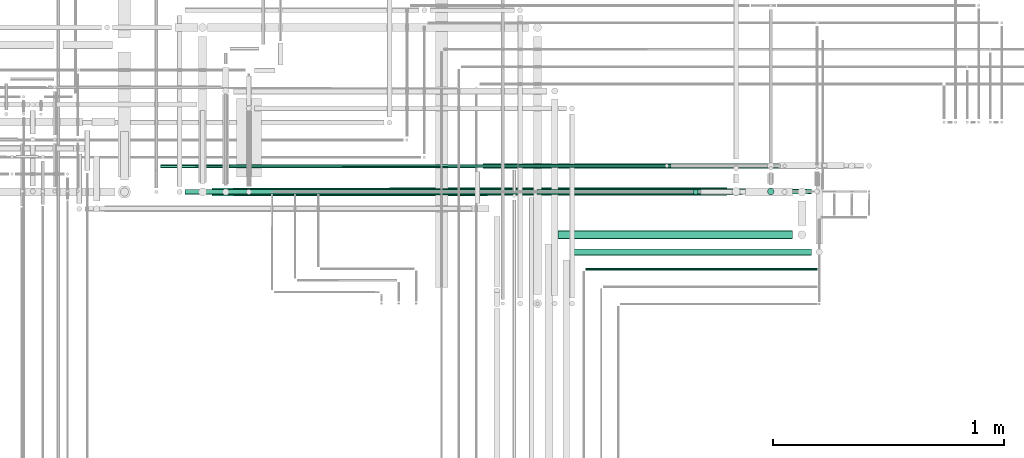
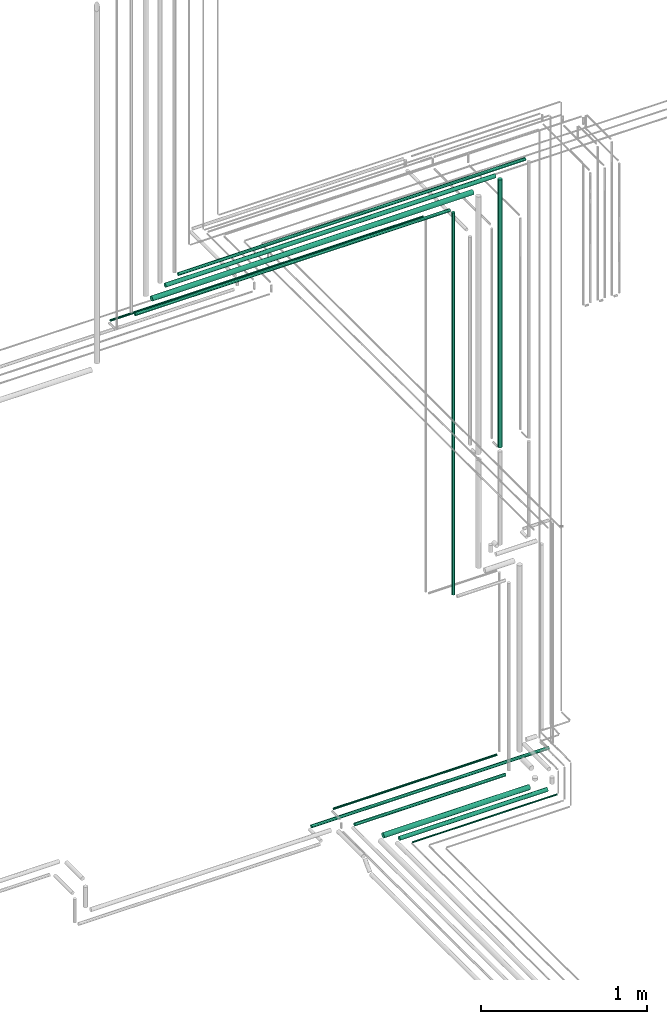
# One storey, part 92 of 331: 13 flow segments.
"""IFC2X3 building model written with IfcOpenShell, lengths in millimetres."""

from ifc_helpers import new_model, entity, si_unit, converted_unit, derived_unit, direction, frame, frame_2d, origin, origin_2d_with_axis, place, context, subcontext, project, spatial, circle, extrude, type_object, element, save


model = new_model("IFC2X3")

# Units and contexts
model_context = context("Model", 3, precision=0.01, world=origin(), true_north=direction((6.12303176911189e-17, 1.0)))
body_context = subcontext(model_context, "Body", "Model", "MODEL_VIEW")
ifc_project = project(units=[si_unit("LENGTHUNIT", "METRE", prefix="MILLI"), si_unit("AREAUNIT", "SQUARE_METRE"), si_unit("VOLUMEUNIT", "CUBIC_METRE"), converted_unit("PLANEANGLEUNIT", "DEGREE", entity("IfcRatioMeasure", 0.0174532925199433), si_unit("PLANEANGLEUNIT", "RADIAN"), dimensions=[0, 0, 0, 0, 0, 0, 0]), si_unit("MASSUNIT", "GRAM", prefix="KILO"), derived_unit("MASSDENSITYUNIT", [(si_unit("MASSUNIT", "GRAM", prefix="KILO"), 1), (si_unit("LENGTHUNIT", "METRE"), -3)]), derived_unit("MOMENTOFINERTIAUNIT", [(si_unit("LENGTHUNIT", "METRE"), 4)]), si_unit("TIMEUNIT", "SECOND"), si_unit("FREQUENCYUNIT", "HERTZ"), si_unit("THERMODYNAMICTEMPERATUREUNIT", "DEGREE_CELSIUS"), derived_unit("THERMALTRANSMITTANCEUNIT", [(si_unit("MASSUNIT", "GRAM", prefix="KILO"), 1), (si_unit("THERMODYNAMICTEMPERATUREUNIT", "KELVIN"), -1), (si_unit("TIMEUNIT", "SECOND"), -3)]), derived_unit("VOLUMETRICFLOWRATEUNIT", [(si_unit("LENGTHUNIT", "METRE"), 3), (si_unit("TIMEUNIT", "SECOND"), -1)]), derived_unit("MASSFLOWRATEUNIT", [(si_unit("MASSUNIT", "GRAM", prefix="KILO"), 1), (si_unit("TIMEUNIT", "SECOND"), -1)]), derived_unit("ROTATIONALFREQUENCYUNIT", [(si_unit("TIMEUNIT", "SECOND"), -1)]), si_unit("ELECTRICCURRENTUNIT", "AMPERE"), si_unit("ELECTRICVOLTAGEUNIT", "VOLT"), si_unit("POWERUNIT", "WATT"), si_unit("FORCEUNIT", "NEWTON", prefix="KILO"), si_unit("ILLUMINANCEUNIT", "LUX"), si_unit("LUMINOUSFLUXUNIT", "LUMEN"), si_unit("LUMINOUSINTENSITYUNIT", "CANDELA"), derived_unit("USERDEFINED", [(si_unit("MASSUNIT", "GRAM", prefix="KILO"), -1), (si_unit("LENGTHUNIT", "METRE"), -2), (si_unit("TIMEUNIT", "SECOND"), 3), (si_unit("LUMINOUSFLUXUNIT", "LUMEN"), 1)]), derived_unit("LINEARVELOCITYUNIT", [(si_unit("LENGTHUNIT", "METRE"), 1), (si_unit("TIMEUNIT", "SECOND"), -1)]), si_unit("PRESSUREUNIT", "PASCAL"), derived_unit("USERDEFINED", [(si_unit("LENGTHUNIT", "METRE"), -2), (si_unit("MASSUNIT", "GRAM", prefix="KILO"), 1), (si_unit("TIMEUNIT", "SECOND"), -2)]), derived_unit("LINEARFORCEUNIT", [(si_unit("MASSUNIT", "GRAM", prefix="KILO"), 1), (si_unit("LENGTHUNIT", "METRE"), 1), (si_unit("TIMEUNIT", "SECOND"), -2), (si_unit("LENGTHUNIT", "METRE"), -1)]), derived_unit("PLANARFORCEUNIT", [(si_unit("MASSUNIT", "GRAM", prefix="KILO"), 1), (si_unit("LENGTHUNIT", "METRE"), 1), (si_unit("TIMEUNIT", "SECOND"), -2), (si_unit("LENGTHUNIT", "METRE"), -2)])], contexts=[model_context])

# Site, building, storey
site_placement = place(None, frame((0.0, -0.00077364408347762, 0.0)))
site = spatial("IfcSite", under=ifc_project, at=site_placement, CompositionType="ELEMENT")
building_placement = place(site_placement, origin())
building = spatial("IfcBuilding", under=site, at=building_placement, CompositionType="ELEMENT")
storey_placement = place(building_placement, origin())
storey = spatial("IfcBuildingStorey", under=building, at=storey_placement, CompositionType="ELEMENT", Elevation=0.0)

# Flow segments
pipe_segment_type = type_object("IfcPipeSegmentType", PredefinedType="NOTDEFINED")
flow_segment_1_placement = place(building_placement, frame((65499.111903194, 8135.3349946452, 2687.40472776407)))
element("IfcFlowSegment", 1, at=flow_segment_1_placement, inside=storey, type_object=pipe_segment_type, context=body_context, shape_type="SweptSolid", body=[
    extrude(circle(Radius=11.0, at=origin_2d_with_axis()), frame((0.0, 12.5952722359156, 12.5952722359161), z_axis=(1.0, 0.0, 0.0), x_axis=(0.0, 1.0, 0.0)), (0.0, 0.0, 1.0), 1046.88542346619),
])
flow_segment_2_placement = place(building_placement, frame((65418.1119031939, 8251.90537015913, 2765.90472776408)))
element("IfcFlowSegment", 2, at=flow_segment_2_placement, inside=storey, type_object=pipe_segment_type, context=body_context, shape_type="SweptSolid", body=[
    extrude(circle(Radius=7.5, at=origin_2d_with_axis()), frame((0.0, 9.09527223591636, 9.09527223591582), z_axis=(1.0, 0.0, 0.0), x_axis=(0.0, -1.0, 0.0)), (0.0, 0.0, 1.0), 1133.88542128677),
])
flow_segment_3_placement = place(building_placement, frame((65590.1119031939, 7943.83499464521, 2680.90472776407)))
element("IfcFlowSegment", 3, at=flow_segment_3_placement, inside=storey, type_object=pipe_segment_type, context=body_context, shape_type="SweptSolid", body=[
    extrude(circle(Radius=17.5, at=frame_2d((-8.66293703438714e-12, 0.0), x_axis=(1.0, 0.0))), frame((0.0, 19.0952722359249, 19.0952722359157), z_axis=(1.0, 0.0, 0.0), x_axis=(0.0, 1.0, 0.0)), (0.0, 0.0, 1.0), 1014.88542346619),
])
flow_segment_4_placement = place(building_placement, frame((65659.1119031939, 7872.33499464522, 2684.40472776407)))
element("IfcFlowSegment", 4, at=flow_segment_4_placement, inside=storey, type_object=pipe_segment_type, context=body_context, shape_type="SweptSolid", body=[
    extrude(circle(Radius=14.0, at=frame_2d((-4.33146851719357e-12, 0.0), x_axis=(1.0, 0.0))), frame((0.0, 15.5952722359203, 15.5952722359154), z_axis=(1.0, 0.0, 0.0), x_axis=(0.0, 1.0, 0.0)), (0.0, 0.0, 1.0), 1026.88542346622),
])
flow_segment_5_placement = place(building_placement, frame((65709.1119031939, 7807.33499464522, 2694.40472776408)))
element("IfcFlowSegment", 5, at=flow_segment_5_placement, inside=storey, type_object=pipe_segment_type, context=body_context, shape_type="SweptSolid", body=[
    extrude(circle(Radius=4.0, at=frame_2d((-2.16573425859679e-12, 0.0), x_axis=(1.0, 0.0))), frame((0.0, 5.59527223591932, 5.59527223591553), z_axis=(1.0, 0.0, 0.0), x_axis=(0.0, 1.0, 0.0)), (0.0, 0.0, 1.0), 1001.8854234662),
])
flow_segment_6_placement = place(building_placement, frame((65264.2002478101, 8248.40537015913, 2687.40472776407)))
element("IfcFlowSegment", 6, at=flow_segment_6_placement, inside=storey, type_object=pipe_segment_type, context=body_context, shape_type="SweptSolid", body=[
    extrude(circle(Radius=11.0, at=origin_2d_with_axis()), frame((0.0, 12.5952722359156, 12.5952722359161), z_axis=(1.0, 0.0, 0.0), x_axis=(0.0, -1.0, 0.0)), (0.0, 0.0, 1.0), 1646.91163546761),
])
flow_segment_7_placement = place(building_placement, frame((66172.5166110417, 8135.3349946452, 4149.00003043299)))
element("IfcFlowSegment", 7, at=flow_segment_7_placement, inside=storey, type_object=pipe_segment_type, context=body_context, shape_type="SweptSolid", body=[
    extrude(circle(Radius=11.0, at=origin_2d_with_axis()), frame((12.5952722359134, 12.5952722359156, 0.0), z_axis=(0.0, 0.0, 1.0), x_axis=(-1.0, 0.0, 0.0)), (0.0, 0.0, 1.0), 2801.99996956704),
])
flow_segment_8_placement = place(building_placement, frame((66494.5166110417, 8134.4053701591, 5115.0)))
element("IfcFlowSegment", 8, at=flow_segment_8_placement, inside=storey, type_object=pipe_segment_type, context=body_context, shape_type="SweptSolid", body=[
    extrude(circle(Radius=14.0, at=origin_2d_with_axis()), frame((15.5952722359127, 15.595272235916, 0.0), z_axis=(0.0, 0.0, 1.0), x_axis=(-1.0, 0.0, 0.0)), (0.0, 0.0, 1.0), 1966.00000000004),
])
flow_segment_9_placement = place(building_placement, frame((63869.0067470385, 8249.9602035719, 6890.90475833634)))
element("IfcFlowSegment", 9, at=flow_segment_9_placement, inside=storey, type_object=pipe_segment_type, context=body_context, shape_type="SweptSolid", body=[
    extrude(circle(Radius=7.5, at=origin_2d_with_axis()), frame((0.00665492805605936, 9.09526928337626, 9.09527223591636), z_axis=(0.999999606328212, 0.000887323741078575, 0.0), x_axis=(-0.000887323741078575, 0.999999606328212, 0.0)), (0.0, 0.0, 1.0), 2173.09934373556),
])
flow_segment_10_placement = place(building_placement, frame((63975.1111934349, 8135.33649963811, 6962.40472776413)))
element("IfcFlowSegment", 10, at=flow_segment_10_placement, inside=storey, type_object=pipe_segment_type, context=body_context, shape_type="SweptSolid", body=[
    extrude(circle(Radius=11.0, at=origin_2d_with_axis()), frame((0.000689778495416249, 12.7323500144915, 12.5952722359156), z_axis=(1.0, -6.27071362883868e-05, 0.0), x_axis=(6.27071362883868e-05, 1.0, 0.0)), (0.0, 0.0, 1.0), 2186.00000440931),
])
flow_segment_11_placement = place(building_placement, frame((64091.0965068524, 8128.92647441681, 7030.90472776414)))
element("IfcFlowSegment", 11, at=flow_segment_11_placement, inside=storey, type_object=pipe_segment_type, context=body_context, shape_type="SweptSolid", body=[
    extrude(circle(Radius=17.5, at=origin_2d_with_axis()), frame((0.01542923698712, 19.0952654341614, 19.0952722359163), z_axis=(0.999999611328326, 0.00088167068460346, 0.0), x_axis=(-0.00088167068460346, 0.999999611328326, 0.0)), (0.0, 0.0, 1.0), 2229.00082846823),
])
flow_segment_12_placement = place(building_placement, frame((64185.1009203725, 8132.58373359585, 7099.40472776415)))
element("IfcFlowSegment", 12, at=flow_segment_12_placement, inside=storey, type_object=pipe_segment_type, context=body_context, shape_type="SweptSolid", body=[
    extrude(circle(Radius=14.0, at=frame_2d((0.0, 1.08286712929839e-12), x_axis=(1.0, 0.0))), frame((0.0109522879219639, 15.5952679518944, 15.5952722359149), z_axis=(0.999999693998395, 0.000782306280180613, 0.0), x_axis=(-0.000782306280180613, 0.999999693998395, 0.0)), (0.0, 0.0, 1.0), 2291.0007243581),
])
flow_segment_13_placement = place(building_placement, frame((64275.1037636327, 8135.59932574808, 7152.40472776417)))
element("IfcFlowSegment", 13, at=flow_segment_13_placement, inside=storey, type_object=pipe_segment_type, context=body_context, shape_type="SweptSolid", body=[
    extrude(circle(Radius=11.0, at=origin_2d_with_axis()), frame((0.00815334265676029, 12.5952692142322, 12.5952722359156), z_axis=(0.99999972530163, 0.00074121296916794, 0.0), x_axis=(-0.00074121296916794, 0.99999972530163, 0.0)), (0.0, 0.0, 1.0), 2411.00063610719),
])

save(model, "model.ifc")
